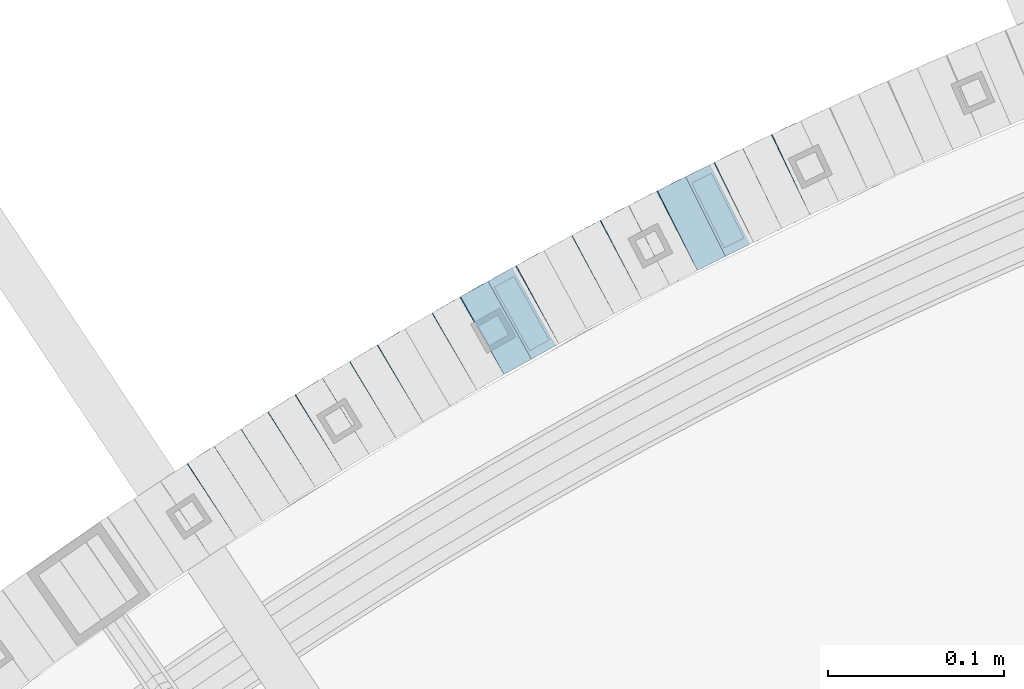
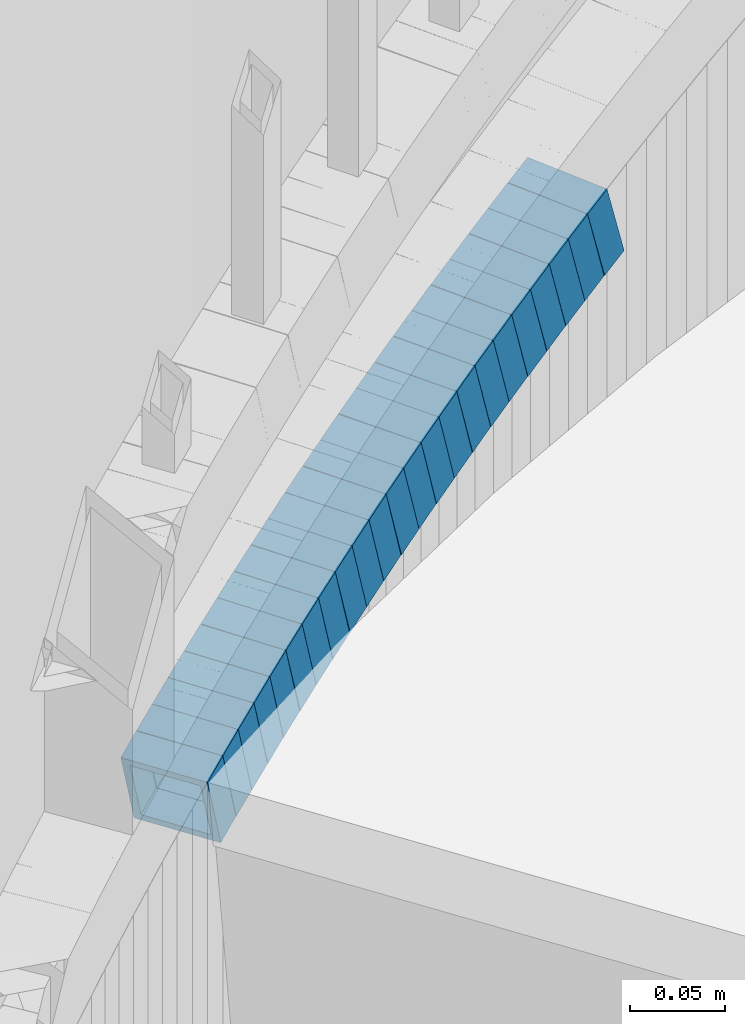
# One storey, part 743 of 975: 23 beams.
"""IFC2X3 building model written with IfcOpenShell, lengths in millimetres."""

import ifcopenshell
import ifcopenshell.guid

model = None  # the IFC model being written
_history = None  # IfcOwnerHistory: only IFC2X3 demands one
_inside = {}  # id of a spatial element -> (the spatial element, [elements in it])
_under = {}  # id of a project, library or spatial element -> (it, [spatial elements below it])
_declared = {}  # id of a project -> (the project, [libraries it declares])
_typed = {}  # id of a type object -> (the type object, [elements of that type])
_made_of = {}  # id of a material, layer set ... -> (it, [elements and type objects made of it])


def new_model(schema):
    """Start an empty IFC model of exactly this schema.

    Asked for "IFC4X3", IfcOpenShell would pick the latest addendum, in which some entities
    have other attributes; the version numbers below select the first issue.
    IFC2X3 requires an IfcOwnerHistory on every rooted entity: one is made here for all.
    """
    global model, _history
    if schema == "IFC4X3":
        model = ifcopenshell.file(schema_version=(4, 3, 0, 0))
    else:
        model = ifcopenshell.file(schema=schema)
    _inside.clear()
    _under.clear()
    _declared.clear()
    _typed.clear()
    _made_of.clear()
    _history = None
    if model.schema == "IFC2X3":
        org = make("IfcOrganization", Name="unknown")
        user = make(
            "IfcPersonAndOrganization",
            ThePerson=make("IfcPerson", FamilyName="unknown"),
            TheOrganization=org,
        )
        app = make(
            "IfcApplication",
            ApplicationDeveloper=org,
            Version="unknown",
            ApplicationFullName="unknown",
            ApplicationIdentifier="unknown",
        )
        _history = make(
            "IfcOwnerHistory",
            OwningUser=user,
            OwningApplication=app,
            ChangeAction="ADDED",
            CreationDate=0,
        )
    return model


def make(cls, **values):
    """One entity of the class cls with the attributes given. An attribute that is None is left unset."""
    return model.create_entity(
        cls, **{name: value for name, value in values.items() if value is not None}
    )


def rooted(cls, **values):
    """An entity with a GlobalId (a new one), such as an element, a storey or a relation."""
    return make(cls, GlobalId=ifcopenshell.guid.new(), OwnerHistory=_history, **values)


def si_unit(unit_type, name, prefix=None):
    """IfcSIUnit, for example si_unit("LENGTHUNIT", "METRE", prefix="MILLI")."""
    return make("IfcSIUnit", UnitType=unit_type, Prefix=prefix, Name=name)


def assignment(units):
    """IfcUnitAssignment: the units of a project."""
    return None if units is None else make("IfcUnitAssignment", Units=units)


def point(xyz):
    """IfcCartesianPoint."""
    return None if xyz is None else make("IfcCartesianPoint", Coordinates=xyz)


def direction(xyz):
    """IfcDirection."""
    return None if xyz is None else make("IfcDirection", DirectionRatios=xyz)


def frame(location, z_axis=None, x_axis=None):
    """IfcAxis2Placement3D, a coordinate frame: its origin and axes. An axis left out is left unset."""
    return make(
        "IfcAxis2Placement3D",
        Location=point(location),
        Axis=direction(z_axis),
        RefDirection=direction(x_axis),
    )


def origin_with_axes():
    """The frame at (0, 0, 0) with the z axis (0, 0, 1) and the x axis (1, 0, 0) written out."""
    return frame((0.0, 0.0, 0.0), z_axis=(0.0, 0.0, 1.0), x_axis=(1.0, 0.0, 0.0))


def place(relative_to, where):
    """IfcLocalPlacement: puts the frame where relative to a parent placement (None: the world)."""
    return make(
        "IfcLocalPlacement", PlacementRelTo=relative_to, RelativePlacement=where
    )


def context(
    kind, dimensions, precision=None, world=None, true_north=None, identifier=None
):
    """IfcGeometricRepresentationContext, for example the 3D "Model" context."""
    return make(
        "IfcGeometricRepresentationContext",
        ContextIdentifier=identifier,
        ContextType=kind,
        CoordinateSpaceDimension=dimensions,
        Precision=precision,
        WorldCoordinateSystem=world,
        TrueNorth=true_north,
    )


def subcontext(parent, identifier, kind, view, scale=None):
    """IfcGeometricRepresentationSubContext, for example "Body" below "Model"."""
    return make(
        "IfcGeometricRepresentationSubContext",
        ContextIdentifier=identifier,
        ContextType=kind,
        ParentContext=parent,
        TargetScale=scale,
        TargetView=view,
    )


def project(units=None, contexts=None):
    """IfcProject with its units and contexts."""
    return rooted(
        "IfcProject",
        Name="project",
        RepresentationContexts=contexts,
        UnitsInContext=assignment(units),
    )


def spatial(cls, under=None, at=None, **own):
    """A site, building, storey or space (cls), placed at a placement, below another one or the project."""
    s = rooted(cls, ObjectPlacement=at, **own)
    if under is not None:
        _under.setdefault(under.id(), (under, []))[1].append(s)
    return s


def faces_of(points, faces, orient=None, outer=None):
    """IfcFace entities. A face is a list of loops; a loop is a list of indices into points, from 0.

    orient and outer hold one flag for each loop. By default every Orientation is true, the
    first loop of a face is its IfcFaceOuterBound and the others are IfcFaceBound.
    """
    made = []
    for i, loops in enumerate(faces):
        bounds = []
        for j, loop in enumerate(loops):
            is_outer = j == 0 if outer is None else outer[i][j]
            bounds.append(
                make(
                    "IfcFaceOuterBound" if is_outer else "IfcFaceBound",
                    Bound=make("IfcPolyLoop", Polygon=[points[k] for k in loop]),
                    Orientation=True if orient is None else orient[i][j],
                )
            )
        made.append(make("IfcFace", Bounds=bounds))
    return made


def faceted_brep(points, faces, orient=None, outer=None, voids=None):
    """IfcFacetedBrep: a solid bounded by flat faces; with voids (closed shells), ...WithVoids."""
    shared = [point(p) for p in points]
    hull = make("IfcClosedShell", CfsFaces=faces_of(shared, faces, orient, outer))
    if voids is None:
        return make("IfcFacetedBrep", Outer=hull)
    return make(
        "IfcFacetedBrepWithVoids",
        Outer=hull,
        Voids=[
            make(cls, CfsFaces=faces_of(shared, fs, o, b)) for cls, fs, o, b in voids
        ],
    )


def shape(context_of_items, identifier, shape_type, items):
    """IfcShapeRepresentation: the items that make up one representation, for example the "Body"."""
    return make(
        "IfcShapeRepresentation",
        ContextOfItems=context_of_items,
        RepresentationIdentifier=identifier,
        RepresentationType=shape_type,
        Items=items,
    )


def material(Name=None, Category=None):
    """IfcMaterial."""
    return make("IfcMaterial", Name=Name, Category=Category)


def made_of(thing, what):
    """Note that an element or type object is made of a material, layer set ...; save() writes the relation."""
    if what is not None:
        _made_of.setdefault(what.id(), (what, []))[1].append(thing)
    return thing


def type_object(cls, material=None, **own):
    """A type object (cls), such as IfcWallType, which elements share."""
    return made_of(rooted(cls, **own), material)


def element(
    cls,
    number,
    at=None,
    inside=None,
    cuts=None,
    type_object=None,
    material=None,
    context=None,
    identifier="Body",
    shape_type=None,
    held_by="IfcProductDefinitionShape",
    body=None,
    shapes=None,
    **own,
):
    """One element of the class cls, such as IfcWall. Its Tag is "e" and its number.

    at: its placement. inside: the storey or other place that contains it. cuts: it is an
    opening in that element (IfcRelVoidsElement). A single representation is given by context,
    identifier, shape_type and body (its items); several are given by shapes. held_by: the class
    of the entity that holds the representations. save() writes the other relations.
    """
    e = rooted(cls, Tag="e%d" % number, ObjectPlacement=at, **own)
    if body is not None:
        shapes = [shape(context, identifier, shape_type, body)]
    if shapes is not None:
        e.Representation = make(held_by, Representations=shapes)
    if inside is not None:
        _inside.setdefault(inside.id(), (inside, []))[1].append(e)
    if cuts is not None:
        rooted(
            "IfcRelVoidsElement", RelatingBuildingElement=cuts, RelatedOpeningElement=e
        )
    if type_object is not None:
        _typed.setdefault(type_object.id(), (type_object, []))[1].append(e)
    return made_of(e, material)


def aggregate(whole, parts):
    """IfcRelAggregates: a whole, such as a stair, and the parts it consists of."""
    return rooted("IfcRelAggregates", RelatingObject=whole, RelatedObjects=parts)


def save(model, path):
    """Write the relations noted so far, then the file.

    IfcRelAggregates (storeys below a building ...), IfcRelContainedInSpatialStructure (elements
    in a storey), IfcRelDefinesByType, IfcRelAssociatesMaterial and IfcRelDeclares: one each for
    every whole, place, type object, material and project.
    """
    for whole, parts in _under.values():
        aggregate(whole, parts)
    for where, things in _inside.values():
        rooted(
            "IfcRelContainedInSpatialStructure",
            RelatedElements=things,
            RelatingStructure=where,
        )
    for kind, things in _typed.values():
        rooted("IfcRelDefinesByType", RelatedObjects=things, RelatingType=kind)
    for what, things in _made_of.values():
        rooted("IfcRelAssociatesMaterial", RelatedObjects=things, RelatingMaterial=what)
    for by, libraries in _declared.values():
        rooted("IfcRelDeclares", RelatingContext=by, RelatedDefinitions=libraries)
    model.write(path)


model = new_model("IFC2X3")

# Units and contexts
model_context = context("Model", 3, precision=1e-05, world=origin_with_axes())
body_context = subcontext(model_context, "Body", "Model", "MODEL_VIEW")
ifc_project = project(units=[si_unit("LENGTHUNIT", "METRE", prefix="MILLI"), si_unit("AREAUNIT", "SQUARE_METRE"), si_unit("VOLUMEUNIT", "CUBIC_METRE"), si_unit("MASSUNIT", "GRAM", prefix="KILO"), si_unit("TIMEUNIT", "SECOND"), si_unit("PLANEANGLEUNIT", "RADIAN"), si_unit("SOLIDANGLEUNIT", "STERADIAN"), si_unit("THERMODYNAMICTEMPERATUREUNIT", "DEGREE_CELSIUS"), si_unit("LUMINOUSINTENSITYUNIT", "LUMEN")], contexts=[model_context])

# Site, building, storey
site_placement = place(None, origin_with_axes())
site = spatial("IfcSite", under=ifc_project, at=site_placement, CompositionType="ELEMENT")
building_placement = place(site_placement, origin_with_axes())
building = spatial("IfcBuilding", under=site, at=building_placement, Name="Undefined", CompositionType="ELEMENT")
storey_placement = place(building_placement, origin_with_axes())
storey = spatial("IfcBuildingStorey", under=building, at=storey_placement, Name="Undefined", CompositionType="ELEMENT", Elevation=0.0)

# Beams
ifc_material = material()
beam_type = type_object("IfcBeamType", Name="HSS2X2X.188_TUBES", PredefinedType="NOTDEFINED")
beam_1_placement = place(storey_placement, frame((33518.7779373334, 6004.0790974917, 641.137552855969), z_axis=(0.424720211576408, -0.905324661035195, -3.22928826790303e-10), x_axis=(-0.861214932569709, -0.404026758267304, -0.308336210204)))
element("IfcBeam", 1, at=beam_1_placement, inside=storey, type_object=beam_type, material=ifc_material, Name="WALL", ObjectType="HSS2X2X.188_TUBES", context=body_context, shape_type="Brep", body=[
    faceted_brep([(0.0, 20.6374999999753, -20.6375000000298), (0.0, -20.6375000000153, -20.6375000000153), (18.8066477608099, -20.6374999999862, -20.6375000000116), (18.8066477608172, 20.6375000000062, -20.6374999999971), (0.0, -20.6374999999825, 20.6375000000335), (18.8066477608463, -20.6375000000062, 20.6375000000407), (0.0, 20.6375000000116, 20.6375000000189), (18.8066477608536, 20.6374999999844, 20.637500000048), (0.0, 25.3999999999724, -25.4000000000342), (0.0, 25.400000000016, 25.4000000000196), (18.8066477608591, 25.3999999999814, 25.400000000056), (18.8066477608154, 25.4000000000051, -25.4000000000015), (0.0, -25.399999999976, 25.4000000000378), (18.8066477608518, -25.4000000000087, 25.4000000000451), (0.0, -25.400000000016, -25.4000000000196), (18.8066477608081, -25.3999999999851, -25.4000000000196)], [[[0, 1, 2, 3]], [[1, 4, 5, 2]], [[4, 6, 7, 5]], [[6, 0, 3, 7]], [[8, 9, 10, 11]], [[9, 12, 13, 10]], [[12, 14, 15, 13]], [[14, 8, 11, 15]], [[13, 15, 11, 10], [5, 7, 3, 2]], [[14, 12, 9, 8], [6, 4, 1, 0]]]),
])
beam_2_placement = place(storey_placement, frame((33502.140574617, 5996.37814892487, 635.298714664072), z_axis=(0.435999194636002, -0.899947055263118, -1.4092199762672e-10), x_axis=(-0.857475412684121, -0.415422870846956, -0.30357825188816)))
element("IfcBeam", 2, at=beam_2_placement, inside=storey, type_object=beam_type, material=ifc_material, Name="WALL", ObjectType="HSS2X2X.188_TUBES", context=body_context, shape_type="Brep", body=[
    faceted_brep([(0.0, 20.6374999999753, -20.6375000000298), (0.0, -20.6375000000153, -20.6375000000153), (18.7771137292038, -20.637500000008, -20.6374999999862), (18.777113729182, 20.6375000000062, -20.6375000000189), (0.0, -20.6374999999825, 20.6375000000335), (18.7771137291729, -20.6374999999916, 20.6374999999753), (0.0, 20.6375000000116, 20.6375000000189), (18.7771137291529, 20.6375000000207, 20.6374999999389), (0.0, 25.3999999999724, -25.4000000000342), (0.0, 25.400000000016, 25.4000000000196), (18.7771137291475, 25.4000000000251, 25.3999999999287), (18.7771137291857, 25.4000000000051, -25.4000000000196), (0.0, -25.399999999976, 25.4000000000378), (18.7771137291711, -25.3999999999905, 25.3999999999724), (0.0, -25.400000000016, -25.4000000000196), (18.7771137292129, -25.4000000000124, -25.3999999999724)], [[[0, 1, 2, 3]], [[1, 4, 5, 2]], [[4, 6, 7, 5]], [[6, 0, 3, 7]], [[8, 9, 10, 11]], [[9, 12, 13, 10]], [[12, 14, 15, 13]], [[14, 8, 11, 15]], [[13, 15, 11, 10], [5, 7, 3, 2]], [[14, 12, 9, 8], [6, 4, 1, 0]]]),
])
beam_3_placement = place(storey_placement, frame((33486.0081337534, 5988.58343090252, 629.610005101873), z_axis=(0.438202247109207, -0.898876404534262, 8.70691110321788e-11), x_axis=(-0.85605573443097, -0.417327170210037, -0.304969855153481)))
element("IfcBeam", 3, at=beam_3_placement, inside=storey, type_object=beam_type, material=ifc_material, Name="WALL", ObjectType="HSS2X2X.188_TUBES", context=body_context, shape_type="Brep", body=[
    faceted_brep([(0.0, 20.6374999999753, -20.6375000000298), (0.0, -20.6375000000153, -20.6375000000153), (18.6895692834223, -20.637499999988, -20.6374999999862), (18.6895692834369, 20.6374999999953, -20.6374999999534), (0.0, -20.6374999999825, 20.6375000000335), (18.6895692833914, -20.637499999988, 20.6374999999789), (0.0, 20.6375000000116, 20.6375000000189), (18.6895692834078, 20.6374999999953, 20.637500000008), (0.0, 25.3999999999724, -25.4000000000342), (0.0, 25.400000000016, 25.4000000000196), (18.6895692834059, 25.3999999999924, 25.4000000000087), (18.6895692834423, 25.3999999999942, -25.3999999999432), (0.0, -25.399999999976, 25.4000000000378), (18.6895692833878, -25.3999999999869, 25.3999999999687), (0.0, -25.400000000016, -25.4000000000196), (18.6895692834241, -25.3999999999869, -25.3999999999833)], [[[0, 1, 2, 3]], [[1, 4, 5, 2]], [[4, 6, 7, 5]], [[6, 0, 3, 7]], [[8, 9, 10, 11]], [[9, 12, 13, 10]], [[12, 14, 15, 13]], [[14, 8, 11, 15]], [[13, 15, 11, 10], [5, 7, 3, 2]], [[14, 12, 9, 8], [6, 4, 1, 0]]]),
])
beam_4_placement = place(storey_placement, frame((33469.8232397528, 5980.77945434369, 623.938270684523), z_axis=(0.447213595270113, -0.894427191114838, 4.34894445788813e-10), x_axis=(-0.850823137641025, -0.425411568820561, -0.308423386869919)))
element("IfcBeam", 4, at=beam_4_placement, inside=storey, type_object=beam_type, material=ifc_material, Name="WALL", ObjectType="HSS2X2X.188_TUBES", context=body_context, shape_type="Brep", body=[
    faceted_brep([(0.0, 20.6374999999753, -20.6375000000298), (0.0, -20.6375000000153, -20.6375000000153), (18.8066477608099, -20.6374999999862, -20.6375000000116), (18.8066477608172, 20.6375000000062, -20.6374999999971), (0.0, -20.6374999999825, 20.6375000000335), (18.8066477608463, -20.6375000000062, 20.6375000000407), (0.0, 20.6375000000116, 20.6375000000189), (18.8066477608536, 20.6374999999844, 20.637500000048), (0.0, 25.3999999999724, -25.4000000000342), (0.0, 25.400000000016, 25.4000000000196), (18.8066477608591, 25.3999999999814, 25.400000000056), (18.8066477608154, 25.4000000000051, -25.4000000000015), (0.0, -25.399999999976, 25.4000000000378), (18.8066477608518, -25.4000000000087, 25.4000000000451), (0.0, -25.400000000016, -25.4000000000196), (18.8066477608081, -25.3999999999851, -25.4000000000196)], [[[0, 1, 2, 3]], [[1, 4, 5, 2]], [[4, 6, 7, 5]], [[6, 0, 3, 7]], [[8, 9, 10, 11]], [[9, 12, 13, 10]], [[12, 14, 15, 13]], [[14, 8, 11, 15]], [[13, 15, 11, 10], [5, 7, 3, 2]], [[14, 12, 9, 8], [6, 4, 1, 0]]]),
])
beam_5_placement = place(storey_placement, frame((33453.7136549116, 5972.72466192308, 618.09888891112), z_axis=(0.447213595270113, -0.894427191114838, 4.34894445788813e-10), x_axis=(-0.852209914200162, -0.426104957100032, -0.303599782071286)))
element("IfcBeam", 5, at=beam_5_placement, inside=storey, type_object=beam_type, material=ifc_material, Name="WALL", ObjectType="HSS2X2X.188_TUBES", context=body_context, shape_type="Brep", body=[
    faceted_brep([(0.0, 20.6374999999753, -20.6375000000298), (0.0, -20.6375000000153, -20.6375000000153), (18.767258723612, -20.6375000000025, -20.6374999999862), (18.7672587236229, 20.6374999999953, -20.637499999968), (0.0, -20.6374999999825, 20.6375000000335), (18.767258723612, -20.6375000000135, 20.6375000000153), (0.0, 20.6375000000116, 20.6375000000189), (18.7672587236266, 20.6374999999844, 20.6375000000371), (0.0, 25.3999999999724, -25.4000000000342), (0.0, 25.400000000016, 25.4000000000196), (18.7672587236302, 25.3999999999814, 25.4000000000342), (18.7672587236229, 25.399999999996, -25.3999999999687), (0.0, -25.399999999976, 25.4000000000378), (18.7672587236157, -25.4000000000142, 25.400000000016), (0.0, -25.400000000016, -25.4000000000196), (18.767258723612, -25.4000000000015, -25.3999999999905)], [[[0, 1, 2, 3]], [[1, 4, 5, 2]], [[4, 6, 7, 5]], [[6, 0, 3, 7]], [[8, 9, 10, 11]], [[9, 12, 13, 10]], [[12, 14, 15, 13]], [[14, 8, 11, 15]], [[13, 15, 11, 10], [5, 7, 3, 2]], [[14, 12, 9, 8], [6, 4, 1, 0]]]),
])
beam_6_placement = place(storey_placement, frame((33437.3864541077, 5964.66659769457, 612.39871466426), z_axis=(0.458358127885069, -0.888767588631412, 2.12838813240524e-11), x_axis=(-0.846823544044361, -0.436726608022841, -0.303578252015872)))
element("IfcBeam", 6, at=beam_6_placement, inside=storey, type_object=beam_type, material=ifc_material, Name="WALL", ObjectType="HSS2X2X.188_TUBES", context=body_context, shape_type="Brep", body=[
    faceted_brep([(0.0, 20.6374999999753, -20.6375000000298), (0.0, -20.6375000000153, -20.6375000000153), (18.7771137292038, -20.637500000008, -20.6374999999862), (18.777113729182, 20.6375000000062, -20.6375000000189), (0.0, -20.6374999999825, 20.6375000000335), (18.7771137291729, -20.6374999999916, 20.6374999999753), (0.0, 20.6375000000116, 20.6375000000189), (18.7771137291529, 20.6375000000207, 20.6374999999389), (0.0, 25.3999999999724, -25.4000000000342), (0.0, 25.400000000016, 25.4000000000196), (18.7771137291475, 25.4000000000251, 25.3999999999287), (18.7771137291857, 25.4000000000051, -25.4000000000196), (0.0, -25.399999999976, 25.4000000000378), (18.7771137291711, -25.3999999999905, 25.3999999999724), (0.0, -25.400000000016, -25.4000000000196), (18.7771137292129, -25.4000000000124, -25.3999999999724)], [[[0, 1, 2, 3]], [[1, 4, 5, 2]], [[4, 6, 7, 5]], [[6, 0, 3, 7]], [[8, 9, 10, 11]], [[9, 12, 13, 10]], [[12, 14, 15, 13]], [[14, 8, 11, 15]], [[13, 15, 11, 10], [5, 7, 3, 2]], [[14, 12, 9, 8], [6, 4, 1, 0]]]),
])
beam_7_placement = place(storey_placement, frame((33421.4502218512, 5956.47025776907, 606.709863101981), z_axis=(0.460645080613948, -0.887584423988034, 2.15908585232683e-10), x_axis=(-0.845306642821246, -0.438703447907129, -0.304952396935443)))
element("IfcBeam", 7, at=beam_7_placement, inside=storey, type_object=beam_type, material=ifc_material, Name="WALL", ObjectType="HSS2X2X.188_TUBES", context=body_context, shape_type="Brep", body=[
    faceted_brep([(0.0, 20.6374999999753, -20.6375000000298), (0.0, -20.6375000000153, -20.6375000000153), (18.6895692834223, -20.637499999988, -20.6374999999862), (18.6895692834369, 20.6374999999953, -20.6374999999534), (0.0, -20.6374999999825, 20.6375000000335), (18.6895692833914, -20.637499999988, 20.6374999999789), (0.0, 20.6375000000116, 20.6375000000189), (18.6895692834078, 20.6374999999953, 20.637500000008), (0.0, 25.3999999999724, -25.4000000000342), (0.0, 25.400000000016, 25.4000000000196), (18.6895692834059, 25.3999999999924, 25.4000000000087), (18.6895692834423, 25.3999999999942, -25.3999999999432), (0.0, -25.399999999976, 25.4000000000378), (18.6895692833878, -25.3999999999869, 25.3999999999687), (0.0, -25.400000000016, -25.4000000000196), (18.6895692834241, -25.3999999999869, -25.3999999999833)], [[[0, 1, 2, 3]], [[1, 4, 5, 2]], [[4, 6, 7, 5]], [[6, 0, 3, 7]], [[8, 9, 10, 11]], [[9, 12, 13, 10]], [[12, 14, 15, 13]], [[14, 8, 11, 15]], [[13, 15, 11, 10], [5, 7, 3, 2]], [[14, 12, 9, 8], [6, 4, 1, 0]]]),
])
beam_8_placement = place(storey_placement, frame((33405.4673012861, 5948.26145027849, 601.037552856301), z_axis=(0.469427602090115, -0.882970965771766, -1.18944626592565e-10), x_axis=(-0.839950366198379, -0.446555891105576, -0.308336210072892)))
element("IfcBeam", 8, at=beam_8_placement, inside=storey, type_object=beam_type, material=ifc_material, Name="WALL", ObjectType="HSS2X2X.188_TUBES", context=body_context, shape_type="Brep", body=[
    faceted_brep([(0.0, 20.6374999999753, -20.6375000000298), (0.0, -20.6375000000153, -20.6375000000153), (18.8066477608099, -20.6374999999862, -20.6375000000116), (18.8066477608172, 20.6375000000062, -20.6374999999971), (0.0, -20.6374999999825, 20.6375000000335), (18.8066477608463, -20.6375000000062, 20.6375000000407), (0.0, 20.6375000000116, 20.6375000000189), (18.8066477608536, 20.6374999999844, 20.637500000048), (0.0, 25.3999999999724, -25.4000000000342), (0.0, 25.400000000016, 25.4000000000196), (18.8066477608591, 25.3999999999814, 25.400000000056), (18.8066477608154, 25.4000000000051, -25.4000000000015), (0.0, -25.399999999976, 25.4000000000378), (18.8066477608518, -25.4000000000087, 25.4000000000451), (0.0, -25.400000000016, -25.4000000000196), (18.8066477608081, -25.3999999999851, -25.4000000000196)], [[[0, 1, 2, 3]], [[1, 4, 5, 2]], [[4, 6, 7, 5]], [[6, 0, 3, 7]], [[8, 9, 10, 11]], [[9, 12, 13, 10]], [[12, 14, 15, 13]], [[14, 8, 11, 15]], [[13, 15, 11, 10], [5, 7, 3, 2]], [[14, 12, 9, 8], [6, 4, 1, 0]]]),
])
for number, where, z_axis, x_axis, name in (
    (9, (33389.3760638156, 5939.77206528319, 595.203296728112), (0.476102697080699, -0.879389687131072, 2.73269051831448e-12), (-0.837729580038792, -0.453547862020962, -0.304143860014047), "WALL"),
    (10, (33373.6760638156, 5931.27206528319, 589.503296728163), (0.476102697080699, -0.879389687131072, 2.73269051831448e-12), (-0.837729580038792, -0.453547862020962, -0.304143860014047), "WALL"),
):
    element("IfcBeam", number, at=place(storey_placement, frame(where, z_axis=z_axis, x_axis=x_axis)), inside=storey, type_object=beam_type, material=ifc_material, Name=name, ObjectType="HSS2X2X.188_TUBES", context=body_context, shape_type="Brep", body=[
        faceted_brep([(0.0, 20.6374999999753, -20.6375000000298), (0.0, -20.6375000000153, -20.6375000000153), (18.7416648140024, -20.6375000000153, -20.6374999999825), (18.7416648139188, 20.6375000000189, -20.6375000000298), (0.0, -20.6374999999825, 20.6375000000335), (18.7416648140097, -20.6375000000189, 20.6375000000226), (0.0, 20.6375000000116, 20.6375000000189), (18.741664813926, 20.6375000000153, 20.6374999999753), (0.0, 25.3999999999724, -25.4000000000342), (0.0, 25.400000000016, 25.4000000000196), (18.7416648139224, 25.4000000000196, 25.3999999999687), (18.7416648139042, 25.4000000000233, -25.4000000000378), (0.0, -25.399999999976, 25.4000000000378), (18.7416648140133, -25.4000000000215, 25.4000000000269), (0.0, -25.400000000016, -25.4000000000196), (18.7416648140133, -25.4000000000196, -25.399999999976)], [[[0, 1, 2, 3]], [[1, 4, 5, 2]], [[4, 6, 7, 5]], [[6, 0, 3, 7]], [[8, 9, 10, 11]], [[9, 12, 13, 10]], [[12, 14, 15, 13]], [[14, 8, 11, 15]], [[13, 15, 11, 10], [5, 7, 3, 2]], [[14, 12, 9, 8], [6, 4, 1, 0]]]),
    ])
beam_9_placement = place(storey_placement, frame((33357.6480106872, 5922.70206240117, 583.802209260096), z_axis=(0.48706831489678, -0.873363874123273, -4.79277559861657e-11), x_axis=(-0.832026625199635, -0.464014849111412, -0.304009728073)))
element("IfcBeam", 11, at=beam_9_placement, inside=storey, type_object=beam_type, material=ifc_material, Name="WALL", ObjectType="HSS2X2X.188_TUBES", context=body_context, shape_type="Brep", body=[
    faceted_brep([(0.0, 20.6374999999753, -20.6375000000298), (0.0, -20.6375000000153, -20.6375000000153), (18.7547327359644, -20.6374999999844, -20.6375000000553), (18.7547327359898, 20.6375000000171, -20.6375000000335), (0.0, -20.6374999999825, 20.6375000000335), (18.7547327360044, -20.6374999999953, 20.6374999999898), (0.0, 20.6375000000116, 20.6375000000189), (18.7547327360262, 20.6375000000062, 20.6375000000116), (0.0, 25.3999999999724, -25.4000000000342), (0.0, 25.400000000016, 25.4000000000196), (18.7547327360371, 25.4000000000033, 25.4000000000124), (18.7547327359898, 25.4000000000178, -25.4000000000342), (0.0, -25.399999999976, 25.4000000000378), (18.7547327360044, -25.399999999996, 25.3999999999869), (0.0, -25.400000000016, -25.4000000000196), (18.7547327359498, -25.3999999999814, -25.4000000000597)], [[[0, 1, 2, 3]], [[1, 4, 5, 2]], [[4, 6, 7, 5]], [[6, 0, 3, 7]], [[8, 9, 10, 11]], [[9, 12, 13, 10]], [[12, 14, 15, 13]], [[14, 8, 11, 15]], [[13, 15, 11, 10], [5, 7, 3, 2]], [[14, 12, 9, 8], [6, 4, 1, 0]]]),
])
beam_10_placement = place(storey_placement, frame((33342.1551292427, 5914.06180159555, 578.141691780704), z_axis=(0.48706831489678, -0.873363874123273, -4.79277559861657e-11), x_axis=(-0.830669042299085, -0.463257735166718, -0.308838490111133)))
element("IfcBeam", 12, at=beam_10_placement, inside=storey, type_object=beam_type, material=ifc_material, Name="WALL", ObjectType="HSS2X2X.188_TUBES", context=body_context, shape_type="Brep", body=[
    faceted_brep([(0.0, 20.6374999999753, -20.6375000000298), (0.0, -20.6375000000153, -20.6375000000153), (18.7771137292038, -20.637500000008, -20.6374999999862), (18.777113729182, 20.6375000000062, -20.6375000000189), (0.0, -20.6374999999825, 20.6375000000335), (18.7771137291729, -20.6374999999916, 20.6374999999753), (0.0, 20.6375000000116, 20.6375000000189), (18.7771137291529, 20.6375000000207, 20.6374999999389), (0.0, 25.3999999999724, -25.4000000000342), (0.0, 25.400000000016, 25.4000000000196), (18.7771137291475, 25.4000000000251, 25.3999999999287), (18.7771137291857, 25.4000000000051, -25.4000000000196), (0.0, -25.399999999976, 25.4000000000378), (18.7771137291711, -25.3999999999905, 25.3999999999724), (0.0, -25.400000000016, -25.4000000000196), (18.7771137292129, -25.4000000000124, -25.3999999999724)], [[[0, 1, 2, 3]], [[1, 4, 5, 2]], [[4, 6, 7, 5]], [[6, 0, 3, 7]], [[8, 9, 10, 11]], [[9, 12, 13, 10]], [[12, 14, 15, 13]], [[14, 8, 11, 15]], [[13, 15, 11, 10], [5, 7, 3, 2]], [[14, 12, 9, 8], [6, 4, 1, 0]]]),
])
beam_11_placement = place(storey_placement, frame((33326.1202980288, 5905.22746351734, 572.300774013054), z_axis=(0.497945444032535, -0.867208357182541, -1.9989442989754e-11), x_axis=(-0.826211457590101, -0.474405288764759, -0.303832600849327)))
element("IfcBeam", 13, at=beam_11_placement, inside=storey, type_object=beam_type, material=ifc_material, Name="WALL", ObjectType="HSS2X2X.188_TUBES", context=body_context, shape_type="Brep", body=[
    faceted_brep([(0.0, 20.6374999999753, -20.6375000000298), (0.0, -20.6375000000153, -20.6375000000153), (18.7555325170906, -20.6374999999916, -20.6374999999971), (18.7555325171452, 20.637499999988, -20.6374999999571), (0.0, -20.6374999999825, 20.6375000000335), (18.7555325170615, -20.6374999999844, 20.6374999999716), (0.0, 20.6375000000116, 20.6375000000189), (18.7555325171015, 20.6374999999953, 20.637500000008), (0.0, 25.3999999999724, -25.4000000000342), (0.0, 25.400000000016, 25.4000000000196), (18.7555325171015, 25.399999999996, 25.4000000000051), (18.7555325171488, 25.3999999999851, -25.3999999999505), (0.0, -25.399999999976, 25.4000000000378), (18.755532517047, -25.3999999999814, 25.3999999999578), (0.0, -25.400000000016, -25.4000000000196), (18.7555325170979, -25.3999999999924, -25.3999999999978)], [[[0, 1, 2, 3]], [[1, 4, 5, 2]], [[4, 6, 7, 5]], [[6, 0, 3, 7]], [[8, 9, 10, 11]], [[9, 12, 13, 10]], [[12, 14, 15, 13]], [[14, 8, 11, 15]], [[13, 15, 11, 10], [5, 7, 3, 2]], [[14, 12, 9, 8], [6, 4, 1, 0]]]),
])
beam_12_placement = place(storey_placement, frame((33310.4348173476, 5896.28833883863, 566.605336642106), z_axis=(0.504568019426507, -0.863371944049615, -2.19346475205384e-10), x_axis=(-0.822401320838062, -0.480624148905325, -0.304395293940039)))
element("IfcBeam", 14, at=beam_12_placement, inside=storey, type_object=beam_type, material=ifc_material, Name="WALL", ObjectType="HSS2X2X.188_TUBES", context=body_context, shape_type="Brep", body=[
    faceted_brep([(0.0, 20.6374999999753, -20.6375000000298), (0.0, -20.6375000000153, -20.6375000000153), (18.7347271129966, -20.6375000000116, -20.6375000000262), (18.7347271130257, 20.6374999999989, -20.6374999999935), (0.0, -20.6374999999825, 20.6375000000335), (18.7347271129947, -20.6375000000116, 20.6374999999607), (0.0, 20.6375000000116, 20.6375000000189), (18.7347271130147, 20.6375000000007, 20.6374999999898), (0.0, 25.3999999999724, -25.4000000000342), (0.0, 25.400000000016, 25.4000000000196), (18.7347271130166, 25.4000000000015, 25.3999999999905), (18.7347271130257, 25.3999999999996, -25.3999999999869), (0.0, -25.399999999976, 25.4000000000378), (18.7347271129875, -25.4000000000106, 25.3999999999505), (0.0, -25.400000000016, -25.4000000000196), (18.7347271130002, -25.4000000000124, -25.4000000000233)], [[[0, 1, 2, 3]], [[1, 4, 5, 2]], [[4, 6, 7, 5]], [[6, 0, 3, 7]], [[8, 9, 10, 11]], [[9, 12, 13, 10]], [[12, 14, 15, 13]], [[14, 8, 11, 15]], [[13, 15, 11, 10], [5, 7, 3, 2]], [[14, 12, 9, 8], [6, 4, 1, 0]]]),
])
beam_13_placement = place(storey_placement, frame((33295.1408166272, 5887.35028646952, 560.944914013525), z_axis=(0.504568019426507, -0.863371944049615, -2.19346475205384e-10), x_axis=(-0.821056045766506, -0.47983794886345, -0.309228899912002)))
element("IfcBeam", 15, at=beam_13_placement, inside=storey, type_object=beam_type, material=ifc_material, Name="WALL", ObjectType="HSS2X2X.188_TUBES", context=body_context, shape_type="Brep", body=[
    faceted_brep([(0.0, 20.6374999999753, -20.6375000000298), (0.0, -20.6375000000153, -20.6375000000153), (18.7555325170906, -20.6374999999916, -20.6374999999971), (18.7555325171452, 20.637499999988, -20.6374999999571), (0.0, -20.6374999999825, 20.6375000000335), (18.7555325170615, -20.6374999999844, 20.6374999999716), (0.0, 20.6375000000116, 20.6375000000189), (18.7555325171015, 20.6374999999953, 20.637500000008), (0.0, 25.3999999999724, -25.4000000000342), (0.0, 25.400000000016, 25.4000000000196), (18.7555325171015, 25.399999999996, 25.4000000000051), (18.7555325171488, 25.3999999999851, -25.3999999999505), (0.0, -25.399999999976, 25.4000000000378), (18.755532517047, -25.3999999999814, 25.3999999999578), (0.0, -25.400000000016, -25.4000000000196), (18.7555325170979, -25.3999999999924, -25.3999999999978)], [[[0, 1, 2, 3]], [[1, 4, 5, 2]], [[4, 6, 7, 5]], [[6, 0, 3, 7]], [[8, 9, 10, 11]], [[9, 12, 13, 10]], [[12, 14, 15, 13]], [[14, 8, 11, 15]], [[13, 15, 11, 10], [5, 7, 3, 2]], [[14, 12, 9, 8], [6, 4, 1, 0]]]),
])
beam_14_placement = place(storey_placement, frame((33279.352276273, 5878.20761077639, 555.092647789874), z_axis=(0.51285525212439, -0.858475095951204, -8.52323864819481e-11), x_axis=(-0.81816570965145, -0.488774319791752, -0.302827567870974)))
element("IfcBeam", 16, at=beam_14_placement, inside=storey, type_object=beam_type, material=ifc_material, Name="WALL", ObjectType="HSS2X2X.188_TUBES", context=body_context, shape_type="Brep", body=[
    faceted_brep([(0.0, 20.6374999999753, -20.6375000000298), (0.0, -20.6375000000153, -20.6375000000153), (18.8225928075335, -20.6374999999935, -20.6375000000298), (18.8225928075699, 20.6374999999898, -20.6374999999825), (0.0, -20.6374999999825, 20.6375000000335), (18.8225928075772, -20.637500000008, 20.6375000000226), (0.0, 20.6375000000116, 20.6375000000189), (18.8225928076135, 20.6374999999753, 20.6375000000698), (0.0, 25.3999999999724, -25.4000000000342), (0.0, 25.400000000016, 25.4000000000196), (18.8225928076281, 25.3999999999705, 25.4000000000815), (18.8225928075663, 25.3999999999905, -25.3999999999796), (0.0, -25.399999999976, 25.4000000000378), (18.8225928075808, -25.4000000000087, 25.4000000000233), (0.0, -25.400000000016, -25.4000000000196), (18.8225928075226, -25.3999999999905, -25.4000000000378)], [[[0, 1, 2, 3]], [[1, 4, 5, 2]], [[4, 6, 7, 5]], [[6, 0, 3, 7]], [[8, 9, 10, 11]], [[9, 12, 13, 10]], [[12, 14, 15, 13]], [[14, 8, 11, 15]], [[13, 15, 11, 10], [5, 7, 3, 2]], [[14, 12, 9, 8], [6, 4, 1, 0]]]),
])
beam_15_placement = place(storey_placement, frame((33263.7665902624, 5868.96455599446, 549.396870758617), z_axis=(0.519415298092746, -0.854521941267294, -1.89692173080402e-11), x_axis=(-0.814256102080105, -0.494939984048606, -0.303350313029803)))
element("IfcBeam", 17, at=beam_15_placement, inside=storey, type_object=beam_type, material=ifc_material, Name="WALL", ObjectType="HSS2X2X.188_TUBES", context=body_context, shape_type="Brep", body=[
    faceted_brep([(0.0, 20.6374999999753, -20.6375000000298), (0.0, -20.6375000000153, -20.6375000000153), (18.7853666454903, -20.6375000000535, -20.6375000000326), (18.785366645363, 20.6374999999862, -20.6375000000044), (0.0, -20.6374999999825, 20.6375000000335), (18.785366645352, -20.6375000000007, 20.6374999999989), (0.0, 20.6375000000116, 20.6375000000189), (18.7853666453102, 20.6375000000025, 20.6374999999753), (0.0, 25.3999999999724, -25.4000000000342), (0.0, 25.400000000016, 25.4000000000196), (18.7853666452065, 25.4000000000451, 25.4000000000351), (18.7853666453739, 25.3999999999833, -25.400000000006), (0.0, -25.399999999976, 25.4000000000378), (18.7853666497213, -25.399999993424, 25.3999999995158), (0.0, -25.400000000016, -25.4000000000196), (18.7853666455194, -25.4000000000633, -25.4000000000406)], [[[0, 1, 2, 3]], [[1, 4, 5, 2]], [[4, 6, 7, 5]], [[6, 0, 3, 7]], [[8, 9, 10, 11]], [[9, 12, 13, 10]], [[12, 14, 15, 13]], [[14, 8, 11, 15]], [[13, 15, 11, 10], [5, 7, 3, 2]], [[14, 12, 9, 8], [6, 4, 1, 0]]]),
])
beam_16_placement = place(storey_placement, frame((33232.9409407489, 5850.27630376862, 537.894409496983), z_axis=(0.529998939660617, -0.84799830421919, -1.28461010717729e-10), x_axis=(-0.808122035968238, -0.505076271980264, -0.30304576298815)))
element("IfcBeam", 18, at=beam_16_placement, inside=storey, type_object=beam_type, material=ifc_material, Name="WALL", ObjectType="HSS2X2X.188_TUBES", context=body_context, shape_type="Brep", body=[
    faceted_brep([(0.0, 20.6374999999753, -20.6375000000298), (0.0, -20.6375000000153, -20.6375000000153), (18.8066477608099, -20.6374999999862, -20.6375000000116), (18.8066477608172, 20.6375000000062, -20.6374999999971), (0.0, -20.6374999999825, 20.6375000000335), (18.8066477608463, -20.6375000000062, 20.6375000000407), (0.0, 20.6375000000116, 20.6375000000189), (18.8066477608536, 20.6374999999844, 20.637500000048), (0.0, 25.3999999999724, -25.4000000000342), (0.0, 25.400000000016, 25.4000000000196), (18.8066477608591, 25.3999999999814, 25.400000000056), (18.8066477608154, 25.4000000000051, -25.4000000000015), (0.0, -25.399999999976, 25.4000000000378), (18.8066477608518, -25.4000000000087, 25.4000000000451), (0.0, -25.400000000016, -25.4000000000196), (18.8066477608081, -25.3999999999851, -25.4000000000196)], [[[0, 1, 2, 3]], [[1, 4, 5, 2]], [[4, 6, 7, 5]], [[6, 0, 3, 7]], [[8, 9, 10, 11]], [[9, 12, 13, 10]], [[12, 14, 15, 13]], [[14, 8, 11, 15]], [[13, 15, 11, 10], [5, 7, 3, 2]], [[14, 12, 9, 8], [6, 4, 1, 0]]]),
])
beam_17_placement = place(storey_placement, frame((33248.5250595965, 5859.72678640334, 543.74720505404), z_axis=(0.521903929516054, -0.853004272179045, -1.64780090017302e-10), x_axis=(-0.81111957811858, -0.496277110072472, -0.309506155045183)))
element("IfcBeam", 19, at=beam_17_placement, inside=storey, type_object=beam_type, material=ifc_material, Name="WALL", ObjectType="HSS2X2X.188_TUBES", context=body_context, shape_type="Brep", body=[
    faceted_brep([(0.0, 20.6374999999753, -20.6375000000298), (0.0, -20.6375000000153, -20.6375000000153), (18.7416648140024, -20.6375000000153, -20.6374999999825), (18.7416648139188, 20.6375000000189, -20.6375000000298), (0.0, -20.6374999999825, 20.6375000000335), (18.7416648140097, -20.6375000000189, 20.6375000000226), (0.0, 20.6375000000116, 20.6375000000189), (18.741664813926, 20.6375000000153, 20.6374999999753), (0.0, 25.3999999999724, -25.4000000000342), (0.0, 25.400000000016, 25.4000000000196), (18.7416648139224, 25.4000000000196, 25.3999999999687), (18.7416648139042, 25.4000000000233, -25.4000000000378), (0.0, -25.399999999976, 25.4000000000378), (18.7416648140133, -25.4000000000215, 25.4000000000269), (0.0, -25.400000000016, -25.4000000000196), (18.7416648140133, -25.4000000000196, -25.399999999976)], [[[0, 1, 2, 3]], [[1, 4, 5, 2]], [[4, 6, 7, 5]], [[6, 0, 3, 7]], [[8, 9, 10, 11]], [[9, 12, 13, 10]], [[12, 14, 15, 13]], [[14, 8, 11, 15]], [[13, 15, 11, 10], [5, 7, 3, 2]], [[14, 12, 9, 8], [6, 4, 1, 0]]]),
])
beam_18_placement = place(storey_placement, frame((33202.3163220327, 5831.08356819764, 526.39161391889), z_axis=(0.540475947867956, -0.841359465256221, -7.92654191172915e-11), x_axis=(-0.801887983516175, -0.515120095331489, -0.302699437194787)))
element("IfcBeam", 20, at=beam_18_placement, inside=storey, type_object=beam_type, material=ifc_material, Name="WALL", ObjectType="HSS2X2X.188_TUBES", context=body_context, shape_type="Brep", body=[
    faceted_brep([(0.0, 20.6374999999753, -20.6375000000298), (0.0, -20.6375000000153, -20.6375000000153), (18.8332159191086, -20.6374999999916, -20.6375000000153), (18.8332159190923, 20.6375000000062, -20.6375000000335), (0.0, -20.6374999999825, 20.6375000000335), (18.8332159191377, -20.6375000000062, 20.6375000000335), (0.0, 20.6375000000116, 20.6375000000189), (18.8332159191141, 20.6374999999916, 20.6375000000116), (0.0, 25.3999999999724, -25.4000000000342), (0.0, 25.400000000016, 25.4000000000196), (18.8332159191159, 25.3999999999905, 25.4000000000124), (18.8332159190886, 25.4000000000069, -25.4000000000415), (0.0, -25.399999999976, 25.4000000000378), (18.8332159191395, -25.4000000000069, 25.4000000000378), (0.0, -25.400000000016, -25.4000000000196), (18.8332159191104, -25.3999999999905, -25.400000000016)], [[[0, 1, 2, 3]], [[1, 4, 5, 2]], [[4, 6, 7, 5]], [[6, 0, 3, 7]], [[8, 9, 10, 11]], [[9, 12, 13, 10]], [[12, 14, 15, 13]], [[14, 8, 11, 15]], [[13, 15, 11, 10], [5, 7, 3, 2]], [[14, 12, 9, 8], [6, 4, 1, 0]]]),
])
beam_19_placement = place(storey_placement, frame((33217.6575315413, 5840.794412626, 532.237660478087), z_axis=(0.536513822259833, -0.843891532440126, 1.68442170433991e-10), x_axis=(-0.80277140702597, -0.510371226016427, -0.308349282009919)))
element("IfcBeam", 21, at=beam_19_placement, inside=storey, type_object=beam_type, material=ifc_material, Name="WALL", ObjectType="HSS2X2X.188_TUBES", context=body_context, shape_type="Brep", body=[
    faceted_brep([(0.0, 20.6374999999753, -20.6375000000298), (0.0, -20.6375000000153, -20.6375000000153), (18.8066477608099, -20.6374999999862, -20.6375000000116), (18.8066477608172, 20.6375000000062, -20.6374999999971), (0.0, -20.6374999999825, 20.6375000000335), (18.8066477608463, -20.6375000000062, 20.6375000000407), (0.0, 20.6375000000116, 20.6375000000189), (18.8066477608536, 20.6374999999844, 20.637500000048), (0.0, 25.3999999999724, -25.4000000000342), (0.0, 25.400000000016, 25.4000000000196), (18.8066477608591, 25.3999999999814, 25.400000000056), (18.8066477608154, 25.4000000000051, -25.4000000000015), (0.0, -25.399999999976, 25.4000000000378), (18.8066477608518, -25.4000000000087, 25.4000000000451), (0.0, -25.400000000016, -25.4000000000196), (18.8066477608081, -25.3999999999851, -25.4000000000196)], [[[0, 1, 2, 3]], [[1, 4, 5, 2]], [[4, 6, 7, 5]], [[6, 0, 3, 7]], [[8, 9, 10, 11]], [[9, 12, 13, 10]], [[12, 14, 15, 13]], [[14, 8, 11, 15]], [[13, 15, 11, 10], [5, 7, 3, 2]], [[14, 12, 9, 8], [6, 4, 1, 0]]]),
])
beam_20_placement = place(storey_placement, frame((33171.9948143165, 5811.65365613717, 515.027554702924), z_axis=(0.550842208648006, -0.834609406352329, 2.89668150799116e-10), x_axis=(-0.794273631185598, -0.524220597122544, -0.307119137071801)))
element("IfcBeam", 22, at=beam_20_placement, inside=storey, type_object=beam_type, material=ifc_material, Name="WALL", ObjectType="HSS2X2X.188_TUBES", context=body_context, shape_type="Brep", body=[
    faceted_brep([(0.0, 20.6374999999753, -20.6375000000298), (0.0, -20.6375000000153, -20.6375000000153), (18.891267824034, -20.6375000000153, -20.6374999999971), (18.891267824034, 20.6375000000025, -20.637500000008), (0.0, -20.6374999999825, 20.6375000000335), (18.8912678240486, -20.6374999999989, 20.6375000000153), (0.0, 20.6375000000116, 20.6375000000189), (18.8912678240449, 20.6375000000189, 20.6375000000007), (0.0, 25.3999999999724, -25.4000000000342), (0.0, 25.400000000016, 25.4000000000196), (18.8912678240467, 25.4000000000215, 25.4000000000051), (18.8912678240304, 25.4000000000033, -25.4000000000124), (0.0, -25.399999999976, 25.4000000000378), (18.8912678240504, -25.3999999999996, 25.400000000016), (0.0, -25.400000000016, -25.4000000000196), (18.891267824034, -25.4000000000178, -25.3999999999978)], [[[0, 1, 2, 3]], [[1, 4, 5, 2]], [[4, 6, 7, 5]], [[6, 0, 3, 7]], [[8, 9, 10, 11]], [[9, 12, 13, 10]], [[12, 14, 15, 13]], [[14, 8, 11, 15]], [[13, 15, 11, 10], [5, 7, 3, 2]], [[14, 12, 9, 8], [6, 4, 1, 0]]]),
])
beam_21_placement = place(storey_placement, frame((33187.1667004696, 5821.37932127436, 520.702069085453), z_axis=(0.543019139473646, -0.839720319014195, -1.43495412885386e-10), x_axis=(-0.799980089763679, -0.517320457847057, -0.303992433910134)))
element("IfcBeam", 23, at=beam_21_placement, inside=storey, type_object=beam_type, material=ifc_material, Name="WALL", ObjectType="HSS2X2X.188_TUBES", context=body_context, shape_type="Brep", body=[
    faceted_brep([(0.0, 20.6374999999753, -20.6375000000298), (0.0, -20.6375000000153, -20.6375000000153), (18.7547327359644, -20.6374999999844, -20.6375000000553), (18.7547327359898, 20.6375000000171, -20.6375000000335), (0.0, -20.6374999999825, 20.6375000000335), (18.7547327360044, -20.6374999999953, 20.6374999999898), (0.0, 20.6375000000116, 20.6375000000189), (18.7547327360262, 20.6375000000062, 20.6375000000116), (0.0, 25.3999999999724, -25.4000000000342), (0.0, 25.400000000016, 25.4000000000196), (18.7547327360371, 25.4000000000033, 25.4000000000124), (18.7547327359898, 25.4000000000178, -25.4000000000342), (0.0, -25.399999999976, 25.4000000000378), (18.7547327360044, -25.399999999996, 25.3999999999869), (0.0, -25.400000000016, -25.4000000000196), (18.7547327359498, -25.3999999999814, -25.4000000000597)], [[[0, 1, 2, 3]], [[1, 4, 5, 2]], [[4, 6, 7, 5]], [[6, 0, 3, 7]], [[8, 9, 10, 11]], [[9, 12, 13, 10]], [[12, 14, 15, 13]], [[14, 8, 11, 15]], [[13, 15, 11, 10], [5, 7, 3, 2]], [[14, 12, 9, 8], [6, 4, 1, 0]]]),
])

save(model, "model.ifc")
